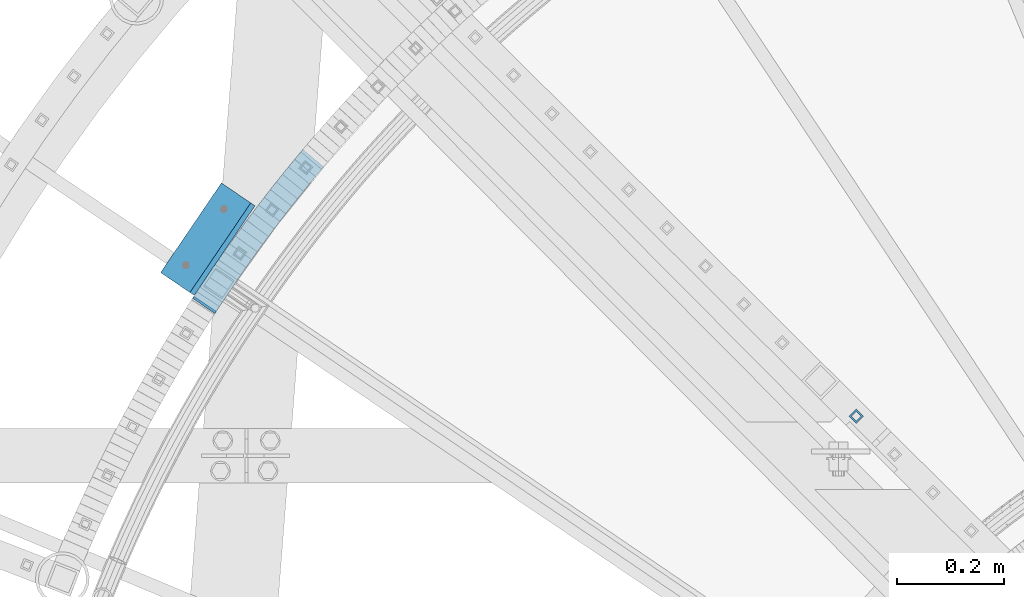
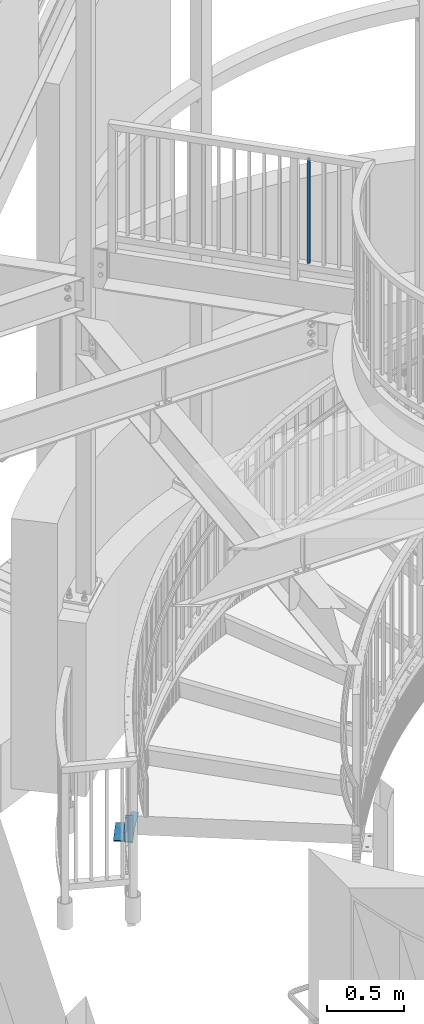
# One storey, part 481 of 975: 4 beams.
"""IFC2X3 building model written with IfcOpenShell, lengths in millimetres."""

from ifc_helpers import new_model, si_unit, frame, origin_with_axes, place, context, subcontext, project, spatial, faceted_brep, material, type_object, element, save


model = new_model("IFC2X3")

# Units and contexts
model_context = context("Model", 3, precision=1e-05, world=origin_with_axes())
body_context = subcontext(model_context, "Body", "Model", "MODEL_VIEW")
ifc_project = project(units=[si_unit("LENGTHUNIT", "METRE", prefix="MILLI"), si_unit("AREAUNIT", "SQUARE_METRE"), si_unit("VOLUMEUNIT", "CUBIC_METRE"), si_unit("MASSUNIT", "GRAM", prefix="KILO"), si_unit("TIMEUNIT", "SECOND"), si_unit("PLANEANGLEUNIT", "RADIAN"), si_unit("SOLIDANGLEUNIT", "STERADIAN"), si_unit("THERMODYNAMICTEMPERATUREUNIT", "DEGREE_CELSIUS"), si_unit("LUMINOUSINTENSITYUNIT", "LUMEN")], contexts=[model_context])

# Site, building, storey
site_placement = place(None, origin_with_axes())
site = spatial("IfcSite", under=ifc_project, at=site_placement, CompositionType="ELEMENT")
building_placement = place(site_placement, origin_with_axes())
building = spatial("IfcBuilding", under=site, at=building_placement, Name="Undefined", CompositionType="ELEMENT")
storey_placement = place(building_placement, origin_with_axes())
storey = spatial("IfcBuildingStorey", under=building, at=storey_placement, Name="Undefined", CompositionType="ELEMENT", Elevation=0.0)

# Beams
ifc_material_1 = material()
beam_type_1 = type_object("IfcBeamType", Name="HSS3/4X3/4X.120_TUBES", PredefinedType="NOTDEFINED")
beam_1_placement = place(storey_placement, frame((33556.3571488115, 4766.96378722623, 4279.9), z_axis=(-0.708992011834517, 0.705216510835392, 0.0), x_axis=(0.0, 0.0, 1.0)))
element("IfcBeam", 1, at=beam_1_placement, inside=storey, type_object=beam_type_1, material=ifc_material_1, Name="PICKET", ObjectType="HSS3/4X3/4X.120_TUBES", context=body_context, shape_type="Brep", body=[
    faceted_brep([(0.0, 6.34999999998763, -6.34999999998763), (0.0, -6.35000000000582, -6.34999999998763), (825.49997943247, -6.35000000000582, -6.34999999998763), (825.49997943247, 6.34999999998763, -6.34999999998763), (0.0, -6.34999999998763, 6.34999999998763), (825.49997943247, -6.34999999998763, 6.34999999998763), (0.0, 6.35000000000946, 6.34999999998763), (825.49997943247, 6.35000000000946, 6.34999999998763), (0.0, 9.52499999997963, -9.52499999997963), (0.0, 9.52500000000873, 9.5249999999869), (825.49997943247, 9.52500000000873, 9.5249999999869), (825.49997943247, 9.52499999997963, -9.52499999997963), (0.0, -9.52499999997963, 9.52499999998327), (825.49997943247, -9.52499999997963, 9.52499999998327), (0.0, -9.52500000000873, -9.5249999999869), (825.49997943247, -9.52500000000873, -9.5249999999869)], [[[0, 1, 2, 3]], [[1, 4, 5, 2]], [[4, 6, 7, 5]], [[6, 0, 3, 7]], [[8, 9, 10, 11]], [[9, 12, 13, 10]], [[12, 14, 15, 13]], [[14, 8, 11, 15]], [[13, 15, 11, 10], [5, 7, 3, 2]], [[14, 12, 9, 8], [6, 4, 1, 0]]]),
])
ifc_material_2 = material(Name="STEEL/A36")
beam_type_2 = type_object("IfcBeamType", PredefinedType="NOTDEFINED")
beam_2_placement = place(storey_placement, frame((32352.5982105689, 4959.70284966019, 2.38162654007597), z_axis=(0.827279193066025, -0.56179100804483, 0.0), x_axis=(0.561791008044794, 0.827279193065973, -3.56000000027958e-07)))
element("IfcBeam", 2, at=beam_2_placement, inside=storey, type_object=beam_type_2, material=ifc_material_2, Name="PLATE", context=body_context, shape_type="Brep", body=[
    faceted_brep([(341.884051910041, 2.38099999999996, -36.7290293437436), (323.792168910815, 2.38099999999996, -38.5765899188191), (305.6020676072, 2.38099999999996, -40.2154516660339), (287.482085064654, 2.38099999999996, -41.7634148199941), (269.349482632133, 2.38099999999997, -43.1863054192727), (251.213016227404, 2.38099999999997, -44.5275976978846), (232.970581761503, 2.38099999999997, -45.7342852815345), (214.877893108249, 2.38099999999997, -46.710244154714), (196.812276864359, 2.38099999999997, -47.6815182417849), (178.649289581186, 2.38099999999998, -48.5958902158527), (160.292183635807, 2.38099999999998, -49.2988352110151), (142.116392919612, 2.38099999999998, -49.9076746018363), (123.806609449985, 2.38099999999998, -50.4020111077589), (105.798719037539, 2.38099999999999, -50.7254911088603), (87.2704297303608, 2.38099999999999, -51.0554277790434), (69.0848796908977, 2.38099999999999, -51.1806250188856), (50.9336155719575, 2.38099999999999, -51.2227086444727), (32.9595983731706, 2.381, -51.1272907825842), (15.1327934478904, 2.381, -50.975182187336), (4.76200004086422, 2.381, -50.806818590594), (2.5465851649642e-11, 2.381, -50.8000001083783), (0.0, 2.38099999999758, 3.63797880709171e-12), (16.0573939847745, 2.381, -0.1850704534736), (33.7522773345081, 2.38099999999999, -0.332462343638326), (51.4192313770582, 2.38099999999999, -0.426089891141601), (69.0032729715313, 2.38099999999999, -0.381213412121724), (86.9207152906056, 2.38099999999999, -0.256632641223405), (104.89225001261, 2.38099999999999, 0.0664192001822812), (122.756973211268, 2.38099999999998, 0.385244354700262), (140.617996150006, 2.38099999999998, 0.869299306512403), (158.591476361551, 2.38099999999998, 1.47268562061436), (176.400161649592, 2.38099999999998, 2.15145797851801), (194.25810230388, 2.38099999999998, 3.05422936092145), (212.152343616057, 2.38099999999997, 4.01658631539613), (229.967056119756, 2.38099999999997, 4.97377053866512), (247.768401919413, 2.38099999999997, 6.15400011076417), (265.602752476752, 2.38099999999997, 7.47533533543174), (283.414520024646, 2.38099999999997, 8.87231600638552), (301.278045382205, 2.38099999999996, 10.4001865710379), (318.979644468862, 2.38099999999996, 11.9918617586518), (336.723174702998, 2.38099999999996, 13.8081348780797), (342.374716470913, 2.38099999999996, 14.3852770655431), (347.535621965446, 2.38099999999996, -36.1518853408052), (336.72317639826, -2.38100000000004, 13.8081348780834), (342.374718166186, -2.38100000000004, 14.3852770655431), (318.979646164134, -2.38100000000004, 11.9918617586554), (301.278047077478, -2.38100000000004, 10.4001865710379), (283.414521719918, -2.38100000000003, 8.87231600638552), (265.602754172021, -2.38100000000003, 7.4753353354281), (247.768403614678, -2.38100000000003, 6.15400011076053), (229.967057815029, -2.38100000000003, 4.97377053866148), (212.152345311326, -2.38100000000002, 4.01658631539613), (194.258103999149, -2.38100000000002, 3.05422936092145), (176.400163344861, -2.38100000000002, 2.15145797851801), (158.591478056824, -2.38100000000002, 1.47268562061436), (140.617997845278, -2.38100000000002, 0.869299306512403), (122.756974906541, -2.38100000000001, 0.385244354700262), (104.892251707879, -2.38100000000001, 0.0664192001786432), (86.9207169858746, -2.38100000000001, -0.256632641223405), (69.0032746668003, -2.38100000000001, -0.381213412125362), (51.4192330723199, -2.38100000000001, -0.426089891145239), (33.7522790297808, -2.381, -0.332462343641964), (16.0573956800436, -2.381, -0.1850704534736), (0.0, -2.38100000000122, -1.81898940354586e-12), (2.18278728425503e-11, -2.381, -50.8000001083783), (4.76200173613688, -2.38100000000058, -50.8068185905977), (15.1327951431631, -2.38100000000054, -50.975182187336), (32.9596000684433, -2.38100000000048, -51.1272907825842), (50.9336172672265, -2.38100000000041, -51.2227086444727), (69.0848813861703, -2.38100000000035, -51.1806250188856), (87.2704314256334, -2.38100000000028, -51.0554277790434), (105.798720732808, -2.38100000000022, -50.7254911088639), (123.806611145257, -2.38100000000015, -50.4020111077589), (142.116394614881, -2.38100000000008, -49.9076746018363), (160.292185331073, -2.38100000000002, -49.2988352110187), (178.649291276459, -2.38099999999995, -48.5958902158527), (196.812278559628, -2.38099999999989, -47.6815182417849), (214.877894803518, -2.38099999999982, -46.7102441547177), (232.970583456772, -2.38099999999976, -45.7342852815345), (251.21301792267, -2.38099999999969, -44.5275976978846), (269.349484327406, -2.38099999999963, -43.1863054192727), (287.482086759926, -2.38099999999956, -41.7634148199941), (305.602069302466, -2.3809999999995, -40.2154516660376), (323.792170606088, -2.38099999999943, -38.5765899188227), (341.884053605314, -2.38099999999936, -36.7290293437436), (347.535623619398, -2.38100000000082, -36.1518849361782)], [[[0, 1, 2, 3, 4, 5, 6, 7, 8, 9, 10, 11, 12, 13, 14, 15, 16, 17, 18, 19, 20, 21, 22, 23, 24, 25, 26, 27, 28, 29, 30, 31, 32, 33, 34, 35, 36, 37, 38, 39, 40, 41, 42]], [[40, 43, 44, 41]], [[43, 45, 46, 47, 48, 49, 50, 51, 52, 53, 54, 55, 56, 57, 58, 59, 60, 61, 62, 63, 64, 65, 66, 67, 68, 69, 70, 71, 72, 73, 74, 75, 76, 77, 78, 79, 80, 81, 82, 83, 84, 85, 44]], [[41, 44, 85, 42]], [[84, 0, 42, 85]], [[83, 1, 0, 84]], [[82, 2, 1, 83]], [[81, 3, 2, 82]], [[80, 4, 3, 81]], [[79, 5, 4, 80]], [[78, 6, 5, 79]], [[77, 7, 6, 78]], [[76, 8, 7, 77]], [[75, 9, 8, 76]], [[74, 10, 9, 75]], [[73, 11, 10, 74]], [[72, 12, 11, 73]], [[71, 13, 12, 72]], [[70, 14, 13, 71]], [[69, 15, 14, 70]], [[68, 16, 15, 69]], [[67, 17, 16, 68]], [[66, 18, 17, 67]], [[65, 19, 18, 66]], [[64, 20, 19, 65]], [[63, 21, 20, 64]], [[62, 22, 21, 63]], [[61, 23, 22, 62]], [[60, 24, 23, 61]], [[59, 25, 24, 60]], [[58, 26, 25, 59]], [[57, 27, 26, 58]], [[56, 28, 27, 57]], [[55, 29, 28, 56]], [[54, 30, 29, 55]], [[53, 31, 30, 54]], [[52, 32, 31, 53]], [[51, 33, 32, 52]], [[50, 34, 33, 51]], [[49, 35, 34, 50]], [[48, 36, 35, 49]], [[47, 37, 36, 48]], [[46, 38, 37, 47]], [[45, 39, 38, 46]], [[43, 40, 39, 45]]]),
])
beam_type_3 = type_object("IfcBeamType", PredefinedType="NOTDEFINED")
beam_3_placement = place(storey_placement, frame((32332.9229442293, 4975.94209425981, 214.666210073612), z_axis=(0.827279193066025, -0.56179100804483, 0.0), x_axis=(0.0, 0.0, -1.0)))
element("IfcBeam", 3, at=beam_3_placement, inside=storey, type_object=beam_type_3, material=ifc_material_2, Name="PLATE", context=body_context, shape_type="Brep", body=[
    faceted_brep([(0.0, -2.3809999999612, -25.3999999999396), (0.0, -2.38100000002669, 25.3999999999396), (0.0, 2.38099999996848, 25.399999999936), (0.0, 2.38100000003396, -25.3999999999432), (209.903557335522, -2.38099999997576, 25.4000000000233), (209.90351866332, 2.38100000002669, 25.4000000000233), (209.90351866332, 2.38099999998303, -25.4000000000124), (209.903557335522, -2.38100000001577, -25.4000000000124)], [[[0, 1, 2, 3]], [[2, 1, 4, 5]], [[3, 2, 5, 6]], [[0, 3, 6, 7]], [[1, 0, 7, 4]], [[6, 5, 4, 7]]]),
])
beam_type_4 = type_object("IfcBeamType", Name="L3X3X3/8", PredefinedType="NOTDEFINED")
beam_4_placement = place(storey_placement, frame((32396.4257760685, 5183.23992187004, 38.1), z_axis=(0.0, 0.0, 1.0), x_axis=(-0.561791008729222, -0.827279192601266, 0.0)))
element("IfcBeam", 4, at=beam_4_placement, inside=storey, type_object=beam_type_4, material=ifc_material_2, Name="ANGLE", ObjectType="L3X3X3/8", context=body_context, shape_type="Brep", body=[
    faceted_brep([(-6.18456397205591e-11, 38.0999999999876, -38.1000000000258), (1.45519152283669e-10, 38.1000000000295, 38.1000000000386), (203.199999998666, 38.0999999999513, 38.1), (203.199999998666, 38.0999999999513, -38.1), (4.72937244921923e-11, 28.5749999999316, 38.1), (203.199999998655, 28.5749999999716, 38.1), (4.72937244921923e-11, 28.5749999999316, -28.575), (203.199999998655, 28.5749999999716, -28.575), (-5.0931703299284e-11, -38.0999999999112, -28.575), (203.199999998556, -38.0999999998749, -28.575), (-1.41881173476577e-10, -38.1000000000258, -38.1000000000386), (203.199999998556, -38.0999999998749, -38.1)], [[[0, 1, 2, 3]], [[1, 4, 5, 2]], [[4, 6, 7, 5]], [[6, 8, 9, 7]], [[8, 10, 11, 9]], [[10, 0, 3, 11]], [[5, 7, 9, 11, 3, 2]], [[10, 8, 6, 4, 1, 0]]]),
])

save(model, "model.ifc")
